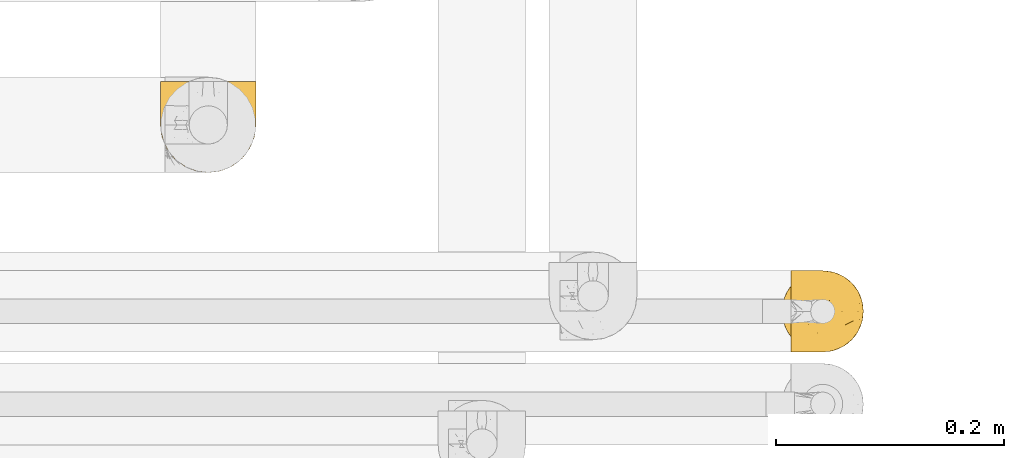
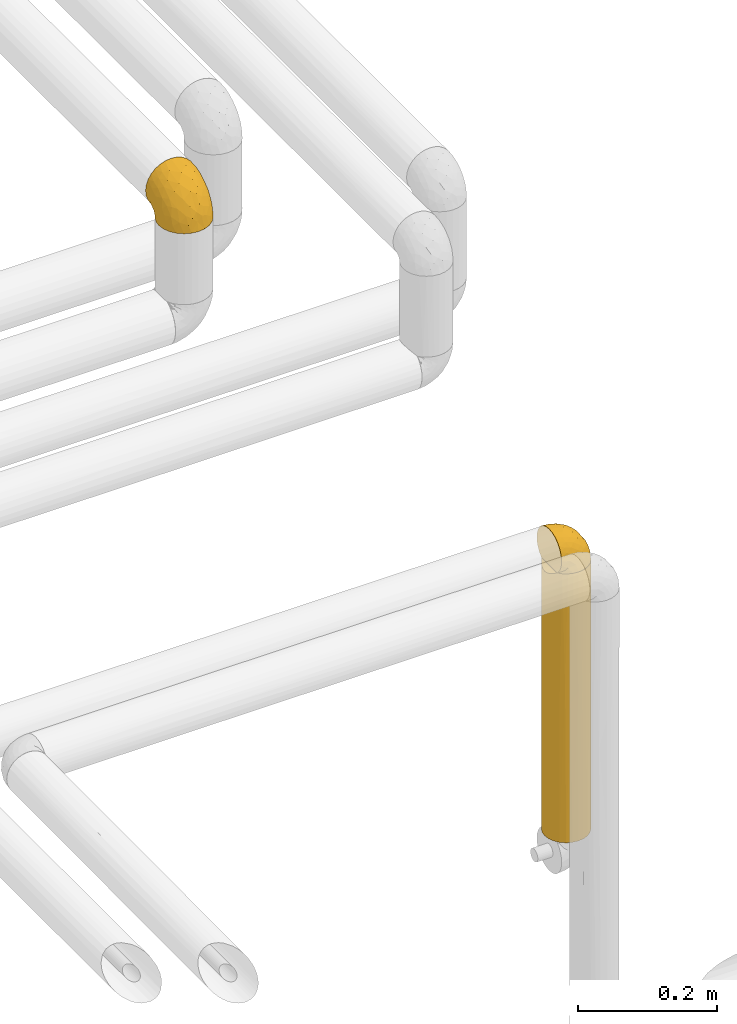
# One storey, part 93 of 827: 3 coverings.
"""IFC2X3 building model written with IfcOpenShell, lengths in millimetres."""

from ifc_helpers import new_model, entity, si_unit, converted_unit, derived_unit, direction, frame, origin, place, context, subcontext, project, spatial, faceted_brep, element, save


model = new_model("IFC2X3")

# Units and contexts
model_context = context("Model", 3, precision=0.01, world=origin(), true_north=direction((6.12303176911189e-17, 1.0)))
body_context = subcontext(model_context, "Body", "Model", "MODEL_VIEW")
ifc_project = project(units=[si_unit("LENGTHUNIT", "METRE", prefix="MILLI"), si_unit("AREAUNIT", "SQUARE_METRE"), si_unit("VOLUMEUNIT", "CUBIC_METRE"), converted_unit("PLANEANGLEUNIT", "DEGREE", entity("IfcRatioMeasure", 0.0174532925199433), si_unit("PLANEANGLEUNIT", "RADIAN"), dimensions=[0, 0, 0, 0, 0, 0, 0]), si_unit("MASSUNIT", "GRAM", prefix="KILO"), derived_unit("MASSDENSITYUNIT", [(si_unit("MASSUNIT", "GRAM", prefix="KILO"), 1), (si_unit("LENGTHUNIT", "METRE"), -3)]), derived_unit("MOMENTOFINERTIAUNIT", [(si_unit("LENGTHUNIT", "METRE"), 4)]), si_unit("TIMEUNIT", "SECOND"), si_unit("FREQUENCYUNIT", "HERTZ"), si_unit("THERMODYNAMICTEMPERATUREUNIT", "DEGREE_CELSIUS"), derived_unit("THERMALTRANSMITTANCEUNIT", [(si_unit("MASSUNIT", "GRAM", prefix="KILO"), 1), (si_unit("THERMODYNAMICTEMPERATUREUNIT", "KELVIN"), -1), (si_unit("TIMEUNIT", "SECOND"), -3)]), derived_unit("VOLUMETRICFLOWRATEUNIT", [(si_unit("LENGTHUNIT", "METRE"), 3), (si_unit("TIMEUNIT", "SECOND"), -1)]), derived_unit("MASSFLOWRATEUNIT", [(si_unit("MASSUNIT", "GRAM", prefix="KILO"), 1), (si_unit("TIMEUNIT", "SECOND"), -1)]), derived_unit("ROTATIONALFREQUENCYUNIT", [(si_unit("TIMEUNIT", "SECOND"), -1)]), si_unit("ELECTRICCURRENTUNIT", "AMPERE"), si_unit("ELECTRICVOLTAGEUNIT", "VOLT"), si_unit("POWERUNIT", "WATT"), si_unit("FORCEUNIT", "NEWTON", prefix="KILO"), si_unit("ILLUMINANCEUNIT", "LUX"), si_unit("LUMINOUSFLUXUNIT", "LUMEN"), si_unit("LUMINOUSINTENSITYUNIT", "CANDELA"), derived_unit("USERDEFINED", [(si_unit("MASSUNIT", "GRAM", prefix="KILO"), -1), (si_unit("LENGTHUNIT", "METRE"), -2), (si_unit("TIMEUNIT", "SECOND"), 3), (si_unit("LUMINOUSFLUXUNIT", "LUMEN"), 1)]), derived_unit("LINEARVELOCITYUNIT", [(si_unit("LENGTHUNIT", "METRE"), 1), (si_unit("TIMEUNIT", "SECOND"), -1)]), si_unit("PRESSUREUNIT", "PASCAL"), derived_unit("USERDEFINED", [(si_unit("LENGTHUNIT", "METRE"), -2), (si_unit("MASSUNIT", "GRAM", prefix="KILO"), 1), (si_unit("TIMEUNIT", "SECOND"), -2)]), derived_unit("LINEARFORCEUNIT", [(si_unit("MASSUNIT", "GRAM", prefix="KILO"), 1), (si_unit("LENGTHUNIT", "METRE"), 1), (si_unit("TIMEUNIT", "SECOND"), -2), (si_unit("LENGTHUNIT", "METRE"), -1)]), derived_unit("PLANARFORCEUNIT", [(si_unit("MASSUNIT", "GRAM", prefix="KILO"), 1), (si_unit("LENGTHUNIT", "METRE"), 1), (si_unit("TIMEUNIT", "SECOND"), -2), (si_unit("LENGTHUNIT", "METRE"), -2)])], contexts=[model_context])

# Site, building, storey
site_placement = place(None, origin())
site = spatial("IfcSite", under=ifc_project, at=site_placement, CompositionType="ELEMENT")
building_placement = place(site_placement, origin())
building = spatial("IfcBuilding", under=site, at=building_placement, CompositionType="ELEMENT")
storey_placement = place(building_placement, frame((0.0, 0.0, 28200.0)))
storey = spatial("IfcBuildingStorey", under=building, at=storey_placement, Name="08", CompositionType="ELEMENT", Elevation=28200.0)

# Coverings
covering_1_placement = place(storey_placement, frame((18847.33, 12899.2, 1400.7)))
element("IfcCovering", 1, at=covering_1_placement, inside=storey, Name=":ADSK_", ObjectType=":ADSK_", PredefinedType="INSULATION", context=body_context, shape_type="Brep", body=[
    faceted_brep([(62.45, 12.04, 471.3), (68.12, 19.42, 471.3), (71.68, 28.02, 471.3), (72.9, 37.25, 471.3), (71.68, 46.47, 471.3), (68.12, 55.07, 471.3), (62.45, 62.45, 471.3), (55.07, 68.12, 471.3), (46.47, 71.68, 471.3), (37.25, 72.9, 471.3), (29.26, 71.99, 471.3), (21.68, 69.32, 471.3), (14.89, 65.02, 471.3), (9.25, 59.31, 471.3), (9.25, 15.18, 471.3), (14.89, 9.47, 471.3), (21.68, 5.17, 471.3), (29.26, 2.5, 471.3), (37.25, 1.6, 471.3), (46.47, 2.81, 471.3), (55.07, 6.37, 471.3), (71.68, 28.02, 0.0), (68.12, 19.42, 0.0), (62.45, 12.04, 0.0), (55.07, 6.37, 0.0), (46.47, 2.81, 0.0), (37.25, 1.6, 0.0), (28.02, 2.81, 0.0), (19.42, 6.37, 0.0), (12.04, 12.04, 0.0), (6.37, 19.42, 0.0), (2.81, 28.02, 0.0), (1.6, 37.25, 0.0), (2.81, 46.47, 0.0), (6.37, 55.07, 0.0), (12.04, 62.45, 0.0), (19.42, 68.12, 0.0), (28.02, 71.68, 0.0), (37.25, 72.9, 0.0), (46.47, 71.68, 0.0), (55.07, 68.12, 0.0), (62.45, 62.45, 0.0), (68.12, 55.07, 0.0), (71.68, 46.47, 0.0), (72.9, 37.25, 0.0), (37.25, 72.9, 262.82), (37.25, 72.9, 235.65), (3.56, 48.92, 465.61), (4.7, 51.79, 229.25), (2.38, 44.7, 252.33), (18.18, 67.37, 268.97), (25.39, 70.87, 243.26), (11.91, 62.32, 249.89), (1.6, 37.25, 255.17), (7.9, 57.48, 177.22), (5.97, 54.35, 468.02), (1.6, 37.25, 463.65), (2.09, 43.17, 464.14), (4.7, 22.7, 229.25), (2.38, 29.79, 252.33), (7.77, 17.19, 292.58), (11.91, 12.17, 249.89), (25.39, 3.62, 243.26), (2.09, 31.32, 464.14), (5.97, 20.14, 468.02), (3.56, 25.57, 465.61), (18.18, 7.12, 268.97), (37.25, 1.6, 262.82), (44.26, 2.29, 278.16), (50.89, 4.31, 238.36), (72.21, 30.29, 276.73), (70.18, 23.6, 235.65), (58.95, 8.96, 235.65), (65.53, 15.54, 238.36), (72.9, 37.25, 235.65), (72.9, 37.25, 262.82), (72.2, 44.26, 278.16), (70.18, 50.89, 238.36), (44.2, 72.21, 276.73), (50.89, 70.18, 235.65), (65.53, 58.95, 235.65), (58.95, 65.53, 238.36)], [[[0, 1, 2, 3, 4, 5, 6, 7, 8, 9, 10, 11, 12, 13, 14, 15, 16, 17, 18, 19, 20]], [[21, 22, 23, 24, 25, 26, 27, 28, 29, 30, 31, 32, 33, 34, 35, 36, 37, 38, 39, 40, 41, 42, 43, 44]], [[37, 45, 46, 38]], [[47, 48, 49]], [[35, 50, 36]], [[36, 51, 37]], [[35, 52, 50]], [[53, 49, 32]], [[37, 51, 45]], [[36, 50, 51]], [[10, 51, 11]], [[51, 50, 11]], [[35, 34, 54]], [[52, 13, 12]], [[11, 50, 12]], [[55, 48, 47]], [[35, 54, 52]], [[33, 49, 48]], [[56, 57, 53]], [[54, 48, 55]], [[53, 57, 49]], [[10, 9, 45]], [[13, 52, 54]], [[34, 33, 48]], [[32, 49, 33]], [[55, 13, 54]], [[45, 51, 10]], [[47, 49, 57]], [[54, 34, 48]], [[12, 50, 52]], [[31, 58, 59]], [[59, 32, 31]], [[30, 60, 58]], [[60, 29, 61]], [[31, 30, 58]], [[62, 17, 16]], [[63, 53, 59]], [[58, 60, 64]], [[58, 64, 65]], [[65, 63, 59]], [[29, 60, 30]], [[63, 56, 53]], [[62, 66, 28]], [[65, 59, 58]], [[28, 27, 62]], [[66, 61, 29]], [[59, 53, 32]], [[67, 18, 17]], [[67, 62, 27]], [[16, 66, 62]], [[66, 29, 28]], [[15, 61, 66]], [[67, 17, 62]], [[60, 61, 14]], [[15, 66, 16]], [[61, 15, 14]], [[64, 60, 14]], [[26, 67, 27]], [[68, 25, 69]], [[21, 70, 71]], [[68, 18, 67, 26]], [[69, 72, 20]], [[72, 69, 24]], [[68, 26, 25]], [[23, 72, 24]], [[72, 0, 20]], [[20, 19, 69]], [[22, 71, 73]], [[70, 44, 74, 75, 3]], [[71, 22, 21]], [[71, 1, 73]], [[23, 73, 72]], [[0, 72, 73]], [[22, 73, 23]], [[68, 69, 19]], [[1, 0, 73]], [[71, 70, 2]], [[1, 71, 2]], [[24, 69, 25]], [[70, 21, 44]], [[18, 68, 19]], [[70, 3, 2]], [[76, 43, 77]], [[39, 78, 79]], [[76, 3, 75, 74, 44]], [[77, 80, 5]], [[80, 77, 42]], [[76, 44, 43]], [[41, 80, 42]], [[80, 6, 5]], [[5, 4, 77]], [[40, 79, 81]], [[78, 38, 46, 45, 9]], [[79, 40, 39]], [[79, 7, 81]], [[41, 81, 80]], [[6, 80, 81]], [[40, 81, 41]], [[76, 77, 4]], [[7, 6, 81]], [[79, 78, 8]], [[7, 79, 8]], [[42, 77, 43]], [[78, 39, 38]], [[3, 76, 4]], [[78, 9, 8]], [[57, 56, 63, 65, 64, 14, 13, 55, 47]]]),
])
covering_2_placement = place(storey_placement, frame((18854.98, 12899.2, 1870.4)))
element("IfcCovering", 2, at=covering_2_placement, inside=storey, Name=":ADSK_", ObjectType=":ADSK_", PredefinedType="INSULATION", context=body_context, shape_type="Brep", body=[
    faceted_brep([(1.6, 5.13, 45.07), (1.6, 9.38, 51.83), (1.6, 15.02, 57.47), (1.6, 21.78, 61.72), (1.6, 29.32, 64.35), (1.6, 37.25, 65.25), (1.6, 45.18, 64.35), (1.6, 52.72, 61.71), (1.6, 59.48, 57.46), (1.6, 65.12, 51.82), (1.6, 69.37, 45.06), (1.6, 72.0, 37.52), (1.6, 72.9, 29.6), (1.6, 72.01, 21.69), (1.6, 69.39, 14.19), (1.6, 65.18, 7.45), (1.6, 59.59, 1.82), (1.6, 57.53, 1.82), (1.6, 56.06, 1.82), (1.6, 54.3, 1.82), (1.6, 52.53, 1.82), (1.6, 50.77, 1.82), (1.6, 49.0, 1.82), (1.6, 47.24, 1.82), (1.6, 45.47, 1.82), (1.6, 43.71, 1.82), (1.6, 41.94, 1.82), (1.6, 40.18, 1.82), (1.6, 38.41, 1.82), (1.6, 36.65, 1.82), (1.6, 34.88, 1.82), (1.6, 33.12, 1.82), (1.6, 31.35, 1.82), (1.6, 29.3, 1.82), (1.6, 27.24, 1.82), (1.6, 25.18, 1.82), (1.6, 23.13, 1.82), (1.6, 21.07, 1.82), (1.6, 19.01, 1.82), (1.6, 16.96, 1.82), (1.6, 14.9, 1.82), (1.6, 9.3, 7.46), (1.6, 5.09, 14.2), (1.6, 2.48, 21.71), (1.6, 1.6, 29.6), (1.6, 2.49, 37.53), (1.82, 59.59, 1.6), (7.46, 65.19, 1.6), (14.2, 69.4, 1.6), (21.7, 72.01, 1.6), (29.6, 72.9, 1.6), (38.82, 71.68, 1.6), (47.42, 68.12, 1.6), (54.8, 62.45, 1.6), (60.47, 55.07, 1.6), (64.03, 46.47, 1.6), (65.25, 37.25, 1.6), (64.03, 28.02, 1.6), (60.47, 19.42, 1.6), (54.8, 12.04, 1.6), (47.42, 6.37, 1.6), (38.82, 2.81, 1.6), (29.6, 1.6, 1.6), (21.7, 2.48, 1.6), (14.2, 5.09, 1.6), (7.46, 9.3, 1.6), (1.82, 14.9, 1.6), (1.82, 15.93, 1.6), (1.82, 17.69, 1.6), (1.82, 19.09, 1.6), (1.82, 20.49, 1.6), (1.82, 21.88, 1.6), (1.82, 23.28, 1.6), (1.82, 24.68, 1.6), (1.82, 26.07, 1.6), (1.82, 27.47, 1.6), (1.82, 28.87, 1.6), (1.82, 30.26, 1.6), (1.82, 31.66, 1.6), (1.82, 33.06, 1.6), (1.82, 34.45, 1.6), (1.82, 35.85, 1.6), (1.82, 37.25, 1.6), (1.82, 39.01, 1.6), (1.82, 40.77, 1.6), (1.82, 42.54, 1.6), (1.82, 44.3, 1.6), (1.82, 46.07, 1.6), (1.82, 47.83, 1.6), (1.82, 49.6, 1.6), (1.82, 51.36, 1.6), (1.82, 53.42, 1.6), (1.82, 55.48, 1.6), (1.82, 57.53, 1.6), (1.75, 24.13, 1.76), (1.76, 22.58, 1.75), (1.76, 46.76, 1.75), (1.76, 45.43, 1.74), (1.74, 51.49, 1.76), (1.76, 35.2, 1.75), (1.75, 58.19, 1.75), (1.75, 56.8, 1.75), (1.75, 32.4, 1.75), (1.76, 30.96, 1.75), (1.74, 16.26, 1.76), (1.75, 14.9, 1.75), (1.74, 28.17, 1.76), (1.76, 26.81, 1.75), (1.75, 55.49, 1.76), (1.75, 44.1, 1.75), (1.74, 42.83, 1.77), (1.76, 36.55, 1.74), (1.76, 37.92, 1.75), (1.76, 29.48, 1.75), (1.73, 39.3, 1.77), (1.74, 48.12, 1.77), (1.75, 49.39, 1.75), (1.74, 17.58, 1.76), (1.75, 33.81, 1.75), (1.78, 41.72, 1.71), (1.76, 54.15, 1.74), (1.76, 52.82, 1.75), (1.75, 40.57, 1.75), (1.76, 21.1, 1.74), (1.75, 19.79, 1.75), (1.75, 59.59, 1.75), (1.76, 25.46, 1.75), (13.11, 70.91, 13.1), (8.18, 68.25, 9.65), (25.84, 72.9, 15.6), (28.13, 72.9, 7.07), (15.6, 72.9, 25.84), (5.2, 64.57, 5.2), (20.72, 72.9, 20.72), (7.07, 72.9, 28.13), (35.56, 46.9, 53.84), (16.98, 49.02, 61.29), (25.95, 37.25, 60.4), (35.4, 72.16, 11.45), (32.74, 72.12, 18.37), (43.51, 65.96, 27.21), (53.51, 58.95, 23.34), (49.6, 65.53, 14.46), (40.07, 70.18, 17.53), (42.61, 70.18, 8.83), (20.45, 67.43, 44.61), (10.52, 67.43, 47.7), (14.87, 62.46, 53.12), (24.92, 72.19, 27.74), (34.61, 53.36, 51.46), (61.84, 43.86, 20.14), (60.43, 50.89, 17.44), (14.29, 37.25, 62.72), (57.0, 58.95, 11.49), (42.79, 55.84, 43.01), (33.34, 59.19, 47.84), (21.53, 71.35, 34.4), (11.52, 70.9, 40.11), (12.66, 56.22, 58.72), (34.11, 67.42, 35.5), (32.29, 70.63, 28.03), (24.41, 61.45, 50.73), (24.95, 56.22, 54.88), (44.19, 48.22, 46.53), (56.24, 51.43, 28.03), (56.83, 45.24, 31.36), (50.94, 50.08, 37.9), (50.38, 43.45, 41.63), (46.6, 37.25, 46.6), (36.28, 37.25, 53.5), (62.72, 37.25, 14.29), (47.39, 59.41, 33.68), (38.92, 62.46, 39.51), (29.55, 64.67, 43.98), (26.82, 68.35, 39.36), (60.4, 37.25, 25.95), (53.5, 37.25, 36.28), (41.8, 4.31, 12.43), (61.8, 30.45, 20.13), (49.33, 25.32, 40.53), (35.54, 27.59, 53.86), (14.87, 12.04, 53.13), (12.65, 18.28, 58.72), (47.44, 8.96, 20.81), (56.06, 15.54, 15.78), (50.17, 16.32, 31.15), (20.44, 7.06, 44.62), (10.52, 7.06, 47.71), (11.52, 3.6, 40.12), (38.79, 19.36, 47.19), (33.87, 2.28, 14.97), (25.84, 1.6, 15.6), (27.72, 1.6, 8.6), (7.07, 1.6, 28.13), (62.13, 25.07, 12.48), (50.52, 8.96, 10.34), (56.47, 29.08, 31.94), (58.39, 23.6, 23.68), (16.98, 25.48, 61.3), (39.3, 7.69, 31.18), (38.56, 4.1, 19.63), (24.94, 18.28, 54.89), (30.34, 2.18, 20.57), (26.49, 2.39, 26.89), (15.6, 1.6, 25.84), (20.72, 1.6, 20.72), (26.6, 12.04, 48.57), (21.54, 3.15, 34.41), (35.7, 2.24, 8.15), (38.91, 12.04, 39.53), (30.65, 6.5, 37.32), (44.9, 11.64, 31.82), (34.09, 3.92, 26.03), (13.11, 3.58, 13.1), (9.65, 6.24, 8.18), (5.2, 9.92, 5.2)], [[[0, 1, 2, 3, 4, 5, 6, 7, 8, 9, 10, 11, 12, 13, 14, 15, 16, 17, 18, 19, 20, 21, 22, 23, 24, 25, 26, 27, 28, 29, 30, 31, 32, 33, 34, 35, 36, 37, 38, 39, 40, 41, 42, 43, 44, 45]], [[46, 47, 48, 49, 50, 51, 52, 53, 54, 55, 56, 57, 58, 59, 60, 61, 62, 63, 64, 65, 66, 67, 68, 69, 70, 71, 72, 73, 74, 75, 76, 77, 78, 79, 80, 81, 82, 83, 84, 85, 86, 87, 88, 89, 90, 91, 92, 93]], [[94, 72, 95]], [[96, 87, 97]], [[20, 98, 21]], [[99, 81, 80]], [[100, 93, 101]], [[102, 103, 32]], [[104, 105, 40]], [[67, 105, 104]], [[106, 107, 34]], [[18, 101, 108]], [[109, 85, 110]], [[36, 94, 95]], [[81, 111, 82]], [[29, 28, 112]], [[17, 101, 18]], [[103, 113, 33]], [[24, 96, 97]], [[28, 114, 112]], [[115, 22, 116]], [[31, 102, 32]], [[68, 104, 117]], [[31, 118, 102]], [[84, 119, 85]], [[120, 91, 121]], [[23, 22, 115]], [[114, 27, 122]], [[123, 37, 95]], [[117, 124, 69]], [[67, 66, 105]], [[104, 39, 117]], [[123, 124, 37]], [[100, 17, 16]], [[100, 125, 46]], [[17, 100, 101]], [[107, 126, 35]], [[92, 108, 101]], [[115, 88, 96]], [[114, 122, 83]], [[101, 93, 92]], [[93, 100, 46]], [[16, 125, 100]], [[108, 19, 18]], [[120, 121, 19]], [[108, 92, 120]], [[19, 108, 120]], [[67, 104, 68]], [[39, 104, 40]], [[69, 68, 117]], [[117, 39, 38]], [[70, 124, 123]], [[124, 70, 69]], [[38, 124, 117]], [[124, 38, 37]], [[72, 71, 95]], [[71, 123, 95]], [[71, 70, 123]], [[126, 94, 35]], [[37, 36, 95]], [[75, 74, 107]], [[73, 72, 94]], [[94, 36, 35]], [[94, 126, 73]], [[74, 73, 126]], [[106, 76, 75]], [[76, 106, 113]], [[113, 106, 33]], [[107, 35, 34]], [[106, 34, 33]], [[126, 107, 74]], [[107, 106, 75]], [[78, 77, 103]], [[77, 113, 103]], [[77, 76, 113]], [[102, 78, 103]], [[33, 32, 103]], [[80, 79, 118]], [[102, 118, 79]], [[112, 111, 29]], [[118, 31, 30]], [[79, 78, 102]], [[99, 111, 81]], [[112, 82, 111]], [[111, 99, 29]], [[30, 29, 99]], [[112, 83, 82]], [[27, 114, 28]], [[99, 118, 30]], [[118, 99, 80]], [[114, 83, 112]], [[84, 83, 122]], [[109, 110, 25]], [[122, 27, 26]], [[119, 110, 85]], [[20, 19, 121]], [[25, 110, 26]], [[91, 120, 92]], [[90, 98, 121]], [[121, 91, 90]], [[23, 115, 96]], [[88, 115, 116]], [[116, 98, 89]], [[89, 88, 116]], [[23, 96, 24]], [[87, 96, 88]], [[25, 24, 109]], [[97, 87, 86]], [[90, 89, 98]], [[116, 22, 21]], [[122, 26, 119]], [[86, 85, 109]], [[109, 97, 86]], [[97, 109, 24]], [[110, 119, 26]], [[122, 119, 84]], [[121, 98, 20]], [[21, 98, 116]], [[48, 127, 49]], [[48, 47, 128]], [[49, 129, 130, 50]], [[129, 49, 127]], [[131, 127, 13]], [[46, 125, 132]], [[16, 15, 132]], [[127, 128, 14]], [[127, 131, 133, 129]], [[14, 13, 127]], [[13, 12, 134, 131]], [[46, 132, 47]], [[48, 128, 127]], [[47, 132, 128]], [[15, 128, 132]], [[125, 16, 132]], [[15, 14, 128]], [[135, 136, 137]], [[138, 129, 139]], [[140, 141, 142]], [[143, 144, 138]], [[145, 146, 147]], [[133, 148, 139]], [[134, 12, 11]], [[136, 135, 149]], [[150, 55, 151]], [[136, 6, 152]], [[153, 54, 53]], [[52, 144, 142]], [[52, 142, 53]], [[54, 153, 151]], [[144, 52, 51]], [[154, 155, 149]], [[156, 131, 157]], [[134, 11, 157]], [[8, 7, 158]], [[147, 9, 8]], [[157, 131, 134]], [[157, 11, 10]], [[146, 157, 10]], [[159, 140, 160]], [[157, 145, 156]], [[161, 162, 155]], [[161, 147, 162]], [[154, 149, 163]], [[150, 164, 165]], [[136, 7, 6]], [[137, 136, 152]], [[162, 158, 136]], [[54, 151, 55]], [[158, 147, 8]], [[166, 167, 165]], [[9, 146, 10]], [[164, 166, 165]], [[168, 135, 137, 169]], [[55, 150, 170]], [[154, 171, 172]], [[139, 148, 160]], [[140, 142, 143]], [[153, 142, 141]], [[51, 50, 130]], [[145, 173, 174]], [[156, 160, 148]], [[6, 5, 152]], [[136, 158, 7]], [[147, 158, 162]], [[147, 146, 9]], [[157, 146, 145]], [[160, 140, 143]], [[140, 172, 171]], [[139, 143, 138]], [[173, 159, 174]], [[170, 150, 175]], [[170, 56, 55]], [[167, 168, 176]], [[176, 175, 165]], [[150, 165, 175]], [[163, 167, 166]], [[176, 165, 167]], [[164, 150, 151]], [[151, 141, 164]], [[171, 164, 141]], [[154, 163, 166]], [[163, 135, 168]], [[166, 164, 171]], [[155, 154, 172]], [[166, 171, 154]], [[140, 171, 141]], [[173, 155, 172]], [[149, 155, 162]], [[159, 173, 172]], [[161, 145, 147]], [[140, 159, 172]], [[174, 160, 156]], [[136, 149, 162]], [[149, 135, 163]], [[155, 173, 161]], [[145, 161, 173]], [[160, 174, 159]], [[156, 148, 131]], [[156, 145, 174]], [[142, 153, 53]], [[151, 153, 141]], [[138, 51, 130]], [[142, 144, 143]], [[51, 138, 144]], [[129, 138, 130]], [[133, 139, 129]], [[160, 143, 139]], [[168, 167, 163]], [[131, 148, 133]], [[60, 177, 61]], [[175, 178, 170]], [[179, 168, 180]], [[178, 57, 170]], [[181, 182, 2]], [[183, 184, 185]], [[186, 187, 188]], [[189, 185, 179]], [[190, 191, 192]], [[45, 193, 188]], [[194, 184, 58]], [[45, 44, 193]], [[59, 195, 60]], [[60, 195, 177]], [[0, 45, 188]], [[196, 179, 197]], [[180, 137, 198]], [[183, 199, 200]], [[201, 182, 181]], [[1, 181, 2]], [[57, 178, 194]], [[198, 3, 182]], [[198, 152, 4]], [[1, 0, 187]], [[190, 202, 191]], [[203, 204, 205]], [[206, 201, 181]], [[186, 188, 207]], [[188, 204, 207]], [[3, 198, 4]], [[58, 184, 59]], [[187, 181, 1]], [[180, 198, 201]], [[206, 181, 186]], [[180, 189, 179]], [[3, 2, 182]], [[180, 168, 169, 137]], [[204, 188, 193]], [[177, 190, 208]], [[209, 210, 199]], [[210, 186, 207]], [[185, 184, 197]], [[195, 184, 183]], [[205, 202, 203]], [[210, 209, 206]], [[179, 185, 197]], [[211, 209, 199]], [[196, 197, 178]], [[180, 201, 189]], [[152, 198, 137]], [[152, 5, 4]], [[61, 208, 62]], [[198, 182, 201]], [[188, 187, 0]], [[181, 187, 186]], [[203, 210, 207]], [[202, 205, 191]], [[199, 210, 212]], [[57, 56, 170]], [[176, 196, 175]], [[178, 197, 194]], [[179, 176, 168]], [[175, 196, 178]], [[176, 179, 196]], [[184, 194, 197]], [[58, 57, 194]], [[208, 190, 192]], [[200, 190, 177]], [[206, 189, 201]], [[185, 189, 209]], [[62, 208, 192]], [[177, 208, 61]], [[210, 206, 186]], [[189, 206, 209]], [[200, 199, 212]], [[211, 183, 185]], [[184, 195, 59]], [[177, 195, 183]], [[183, 200, 177]], [[202, 200, 212]], [[200, 202, 190]], [[202, 212, 203]], [[210, 203, 212]], [[204, 203, 207]], [[183, 211, 199]], [[185, 209, 211]], [[63, 62, 192, 191]], [[64, 63, 213]], [[64, 213, 214]], [[65, 215, 66]], [[213, 191, 205, 204]], [[43, 204, 193, 44]], [[65, 214, 215]], [[42, 213, 43]], [[215, 105, 66]], [[41, 214, 42]], [[40, 105, 215]], [[65, 64, 214]], [[40, 215, 41]], [[213, 63, 191]], [[42, 214, 213]], [[204, 43, 213]], [[214, 41, 215]]]),
])
covering_3_placement = place(storey_placement, frame((18302.11, 13056.55, 2560.4)))
element("IfcCovering", 3, at=covering_3_placement, inside=storey, Name=":ADSK_", ObjectType=":ADSK_", PredefinedType="INSULATION", context=body_context, shape_type="Brep", body=[
    faceted_brep([(5.74, 81.45, 57.76), (10.73, 81.45, 65.69), (17.36, 81.45, 72.32), (25.29, 81.45, 77.3), (34.14, 81.45, 80.4), (43.45, 81.45, 81.45), (52.76, 81.45, 80.39), (61.61, 81.45, 77.3), (69.54, 81.45, 72.31), (76.17, 81.45, 65.68), (81.15, 81.45, 57.75), (84.25, 81.45, 48.9), (85.3, 81.45, 39.6), (84.23, 81.45, 30.22), (81.1, 81.45, 21.33), (76.06, 81.45, 13.37), (69.36, 81.45, 6.73), (61.36, 81.45, 1.77), (60.44, 81.45, 1.77), (59.52, 81.45, 1.77), (58.72, 81.45, 1.77), (57.4, 81.45, 1.77), (56.08, 81.45, 1.77), (54.76, 81.45, 1.77), (53.44, 81.45, 1.77), (52.12, 81.45, 1.77), (50.8, 81.45, 1.77), (49.47, 81.45, 1.77), (48.15, 81.45, 1.77), (46.83, 81.45, 1.77), (45.51, 81.45, 1.77), (44.19, 81.45, 1.77), (42.87, 81.45, 1.77), (41.55, 81.45, 1.77), (40.23, 81.45, 1.77), (39.31, 81.45, 1.77), (38.39, 81.45, 1.77), (37.48, 81.45, 1.77), (36.56, 81.45, 1.77), (35.64, 81.45, 1.77), (34.72, 81.45, 1.77), (33.8, 81.45, 1.77), (32.88, 81.45, 1.77), (31.96, 81.45, 1.77), (31.05, 81.45, 1.77), (30.13, 81.45, 1.77), (29.21, 81.45, 1.77), (28.29, 81.45, 1.77), (27.37, 81.45, 1.77), (26.45, 81.45, 1.77), (25.53, 81.45, 1.77), (17.52, 81.45, 6.74), (10.82, 81.45, 13.38), (5.78, 81.45, 21.35), (2.65, 81.45, 30.24), (1.6, 81.45, 39.6), (2.65, 81.45, 48.91), (69.37, 76.3, 1.6), (76.06, 69.67, 1.6), (81.1, 61.7, 1.6), (84.23, 52.81, 1.6), (85.3, 43.45, 1.6), (83.87, 32.61, 1.6), (79.69, 22.52, 1.6), (73.04, 13.85, 1.6), (64.37, 7.2, 1.6), (54.28, 3.02, 1.6), (43.45, 1.6, 1.6), (32.61, 3.02, 1.6), (22.52, 7.2, 1.6), (13.85, 13.85, 1.6), (7.2, 22.52, 1.6), (3.02, 32.61, 1.6), (1.6, 43.45, 1.6), (2.66, 52.81, 1.6), (5.79, 61.7, 1.6), (10.83, 69.67, 1.6), (17.52, 76.3, 1.6), (25.53, 81.27, 1.6), (26.45, 81.27, 1.6), (27.77, 81.27, 1.6), (28.89, 81.27, 1.6), (30.01, 81.27, 1.6), (31.13, 81.27, 1.6), (32.25, 81.27, 1.6), (33.37, 81.27, 1.6), (34.49, 81.27, 1.6), (35.61, 81.27, 1.6), (36.73, 81.27, 1.6), (37.85, 81.27, 1.6), (38.97, 81.27, 1.6), (40.09, 81.27, 1.6), (41.21, 81.27, 1.6), (42.33, 81.27, 1.6), (43.45, 81.27, 1.6), (44.77, 81.27, 1.6), (46.09, 81.27, 1.6), (47.41, 81.27, 1.6), (48.73, 81.27, 1.6), (50.05, 81.27, 1.6), (51.37, 81.27, 1.6), (52.69, 81.27, 1.6), (54.01, 81.27, 1.6), (54.93, 81.27, 1.6), (55.85, 81.27, 1.6), (56.76, 81.27, 1.6), (57.68, 81.27, 1.6), (58.6, 81.27, 1.6), (59.52, 81.27, 1.6), (60.44, 81.27, 1.6), (61.36, 81.27, 1.6), (32.81, 81.31, 1.71), (31.73, 81.33, 1.73), (50.71, 81.31, 1.71), (51.76, 81.32, 1.72), (42.89, 81.31, 1.71), (41.81, 81.32, 1.72), (25.53, 81.32, 1.72), (26.91, 81.32, 1.72), (40.71, 81.32, 1.72), (60.15, 81.32, 1.72), (39.53, 81.32, 1.72), (57.22, 81.32, 1.72), (58.17, 81.3, 1.7), (47.12, 81.32, 1.72), (33.93, 81.33, 1.73), (35.05, 81.31, 1.72), (46.09, 81.33, 1.73), (45.02, 81.32, 1.73), (43.95, 81.32, 1.72), (59.12, 81.32, 1.72), (38.49, 81.31, 1.71), (49.68, 81.32, 1.72), (53.35, 81.31, 1.71), (54.4, 81.32, 1.72), (56.2, 81.32, 1.72), (36.2, 81.32, 1.72), (37.29, 81.33, 1.73), (30.57, 81.32, 1.72), (29.45, 81.31, 1.71), (28.01, 81.33, 1.73), (61.36, 81.32, 1.72), (25.53, 81.36, 1.74), (25.53, 81.4, 1.75), (61.36, 81.4, 1.75), (61.36, 81.36, 1.74), (25.53, 81.29, 1.64), (61.36, 81.3, 1.68), (61.36, 81.29, 1.64), (55.3, 81.35, 1.74), (48.18, 81.31, 1.71), (82.92, 58.5, 8.98), (85.3, 71.95, 37.05), (82.92, 74.57, 24.69), (78.8, 73.93, 15.28), (78.8, 78.18, 16.86), (70.46, 78.04, 6.58), (71.16, 76.23, 5.71), (85.3, 45.99, 11.1), (76.1, 74.01, 10.79), (72.9, 73.57, 4.13), (78.81, 66.66, 6.62), (72.89, 79.09, 9.52), (74.06, 73.14, 6.14), (83.71, 60.34, 17.79), (85.3, 48.54, 20.6), (85.3, 45.36, 8.73), (83.61, 67.22, 23.66), (85.3, 62.45, 34.5), (80.61, 68.67, 15.32), (85.3, 55.49, 27.55), (67.83, 77.84, 3.31), (78.81, 68.16, 9.81), (85.3, 74.31, 37.68), (54.78, 38.78, 67.23), (57.27, 62.1, 76.64), (43.45, 50.89, 75.37), (84.45, 36.91, 14.58), (84.39, 40.37, 23.71), (77.16, 27.86, 34.34), (68.92, 15.77, 29.1), (76.65, 20.13, 18.02), (82.11, 31.54, 22.27), (82.11, 28.25, 10.97), (78.88, 57.26, 56.79), (78.88, 69.99, 60.76), (73.04, 64.58, 67.04), (84.47, 50.64, 36.11), (65.72, 51.97, 68.85), (51.16, 5.72, 24.58), (59.46, 7.42, 21.54), (43.45, 66.14, 78.4), (68.92, 11.35, 14.11), (51.18, 21.64, 53.42), (57.42, 28.57, 58.19), (83.48, 55.38, 44.49), (82.95, 68.51, 51.77), (65.72, 67.48, 73.69), (78.97, 40.78, 45.89), (82.64, 41.53, 35.97), (75.14, 46.11, 56.55), (68.58, 40.32, 60.03), (61.95, 38.36, 63.64), (58.11, 11.84, 34.98), (51.07, 12.56, 40.58), (43.45, 7.67, 32.15), (58.51, 19.39, 47.26), (43.45, 24.98, 58.06), (43.45, 37.94, 66.71), (43.45, 4.64, 16.9), (65.68, 28.09, 52.08), (70.41, 23.73, 41.21), (73.04, 34.03, 49.76), (43.45, 16.33, 45.11), (4.78, 29.29, 15.65), (35.48, 5.77, 24.57), (29.45, 21.44, 50.54), (32.11, 38.8, 67.25), (13.86, 64.58, 67.06), (21.19, 67.49, 73.7), (10.24, 22.9, 26.13), (17.97, 12.54, 19.54), (18.88, 20.04, 38.96), (8.01, 57.26, 56.8), (8.01, 69.99, 60.77), (3.95, 68.51, 51.78), (22.45, 34.54, 59.09), (2.4, 38.81, 19.25), (1.6, 48.54, 20.6), (1.6, 45.99, 11.1), (1.6, 74.31, 37.68), (29.05, 5.36, 15.21), (10.24, 18.96, 12.76), (35.7, 12.79, 40.93), (29.63, 62.11, 76.65), (8.75, 33.14, 39.5), (4.54, 33.44, 25.01), (21.19, 51.98, 68.86), (2.28, 43.42, 26.7), (2.53, 48.62, 34.95), (1.6, 62.45, 34.5), (1.6, 55.49, 27.55), (13.86, 49.68, 61.27), (3.41, 55.37, 44.5), (1.6, 71.95, 37.05), (2.35, 36.37, 10.25), (13.86, 34.04, 49.78), (7.35, 44.1, 47.51), (27.43, 9.99, 29.38), (13.39, 26.41, 40.01), (4.32, 39.19, 33.36), (3.97, 58.5, 8.98), (3.27, 67.22, 23.67), (3.97, 74.57, 24.71), (8.08, 73.92, 15.29), (13.99, 73.57, 4.13), (12.83, 73.14, 6.14), (8.08, 66.19, 4.96), (8.08, 68.16, 9.81), (19.06, 77.84, 3.31), (15.74, 76.23, 5.7), (25.53, 81.3, 1.68), (13.98, 79.08, 9.53), (16.42, 78.04, 6.59), (8.08, 77.18, 16.63), (6.27, 68.66, 15.34), (10.78, 74.0, 10.8), (3.18, 60.34, 17.79)], [[[0, 1, 2, 3, 4, 5, 6, 7, 8, 9, 10, 11, 12, 13, 14, 15, 16, 17, 18, 19, 20, 21, 22, 23, 24, 25, 26, 27, 28, 29, 30, 31, 32, 33, 34, 35, 36, 37, 38, 39, 40, 41, 42, 43, 44, 45, 46, 47, 48, 49, 50, 51, 52, 53, 54, 55, 56]], [[57, 58, 59, 60, 61, 62, 63, 64, 65, 66, 67, 68, 69, 70, 71, 72, 73, 74, 75, 76, 77, 78, 79, 80, 81, 82, 83, 84, 85, 86, 87, 88, 89, 90, 91, 92, 93, 94, 95, 96, 97, 98, 99, 100, 101, 102, 103, 104, 105, 106, 107, 108, 109, 110]], [[111, 84, 112]], [[113, 26, 114]], [[114, 101, 100]], [[115, 93, 116]], [[79, 117, 118]], [[33, 116, 119]], [[117, 49, 118]], [[19, 18, 120]], [[119, 121, 34]], [[122, 21, 123]], [[97, 96, 124]], [[86, 125, 126]], [[116, 92, 119]], [[127, 96, 128]], [[32, 129, 115]], [[19, 120, 130]], [[121, 90, 131]], [[94, 115, 129]], [[115, 116, 32]], [[118, 49, 48]], [[113, 99, 132]], [[133, 114, 25]], [[24, 134, 133]], [[135, 22, 122]], [[136, 137, 88]], [[84, 83, 112]], [[138, 82, 139]], [[130, 20, 19]], [[118, 48, 140]], [[81, 140, 139]], [[123, 21, 20]], [[141, 120, 18]], [[139, 82, 81]], [[130, 107, 123]], [[49, 117, 142, 143, 50]], [[18, 17, 144, 145, 141]], [[79, 78, 146]], [[109, 141, 147, 148]], [[102, 133, 134]], [[105, 135, 122]], [[118, 80, 79]], [[80, 118, 140]], [[120, 109, 108]], [[47, 46, 140, 48]], [[81, 80, 140]], [[44, 112, 138]], [[93, 115, 94]], [[46, 139, 140]], [[46, 45, 139]], [[139, 45, 138]], [[138, 112, 83]], [[85, 84, 111]], [[112, 43, 111]], [[83, 82, 138]], [[106, 122, 123]], [[105, 122, 106]], [[21, 122, 22]], [[124, 29, 28]], [[33, 32, 116]], [[128, 129, 31]], [[32, 31, 129]], [[34, 33, 119]], [[116, 93, 92]], [[129, 95, 94]], [[95, 129, 128]], [[41, 40, 125, 42]], [[119, 91, 121]], [[36, 35, 131, 37]], [[137, 131, 89]], [[121, 131, 35]], [[90, 121, 91]], [[119, 92, 91]], [[136, 126, 39]], [[125, 86, 85]], [[42, 125, 111]], [[85, 111, 125]], [[149, 23, 22]], [[130, 108, 107]], [[130, 123, 20]], [[107, 106, 123]], [[137, 37, 131]], [[136, 38, 137]], [[89, 88, 137]], [[131, 90, 89]], [[124, 150, 97]], [[40, 39, 126]], [[87, 126, 136]], [[86, 126, 87]], [[136, 88, 87]], [[40, 126, 125]], [[39, 38, 136]], [[95, 128, 96]], [[30, 128, 31]], [[29, 124, 127]], [[127, 128, 30]], [[150, 124, 28]], [[127, 30, 29]], [[127, 124, 96]], [[150, 98, 97]], [[45, 44, 138]], [[26, 113, 132]], [[113, 100, 99]], [[132, 150, 27]], [[27, 26, 132]], [[26, 25, 114]], [[100, 113, 114]], [[101, 133, 102]], [[133, 101, 114]], [[28, 27, 150]], [[132, 99, 98]], [[23, 134, 24]], [[25, 24, 133]], [[134, 23, 149]], [[135, 104, 149]], [[149, 104, 103]], [[103, 102, 134]], [[130, 120, 108]], [[109, 120, 141]], [[42, 111, 43]], [[112, 44, 43]], [[104, 135, 105]], [[134, 149, 103]], [[135, 149, 22]], [[35, 34, 121]], [[137, 38, 37]], [[98, 150, 132]], [[59, 151, 60]], [[13, 152, 153]], [[154, 155, 153]], [[156, 157, 141]], [[158, 60, 151]], [[159, 156, 154]], [[160, 161, 58]], [[58, 161, 59]], [[144, 16, 162]], [[58, 57, 160]], [[161, 160, 163]], [[156, 162, 154]], [[162, 16, 15]], [[57, 148, 160]], [[151, 164, 165]], [[156, 144, 162]], [[60, 158, 166, 61]], [[155, 14, 153]], [[162, 155, 154]], [[154, 153, 167]], [[167, 153, 168]], [[154, 169, 159]], [[57, 110, 148]], [[144, 17, 16]], [[155, 15, 14]], [[170, 164, 167]], [[157, 163, 171]], [[14, 13, 153]], [[156, 141, 145, 144]], [[172, 163, 157]], [[172, 159, 169]], [[170, 165, 164]], [[167, 164, 169]], [[167, 168, 170]], [[151, 172, 164]], [[169, 154, 167]], [[164, 172, 169]], [[159, 172, 157]], [[171, 148, 147]], [[147, 141, 157]], [[157, 156, 159]], [[151, 165, 158]], [[172, 151, 161]], [[59, 161, 151]], [[13, 12, 173, 152]], [[152, 168, 153]], [[15, 155, 162]], [[161, 163, 172]], [[171, 163, 160]], [[148, 171, 160]], [[157, 171, 147]], [[174, 175, 176]], [[177, 165, 178]], [[179, 180, 181]], [[182, 183, 177]], [[184, 185, 186]], [[170, 187, 178]], [[173, 12, 11]], [[188, 175, 174]], [[189, 66, 190]], [[175, 6, 191]], [[192, 65, 64]], [[63, 183, 181]], [[63, 181, 64]], [[65, 192, 190]], [[183, 63, 62]], [[174, 193, 194]], [[195, 168, 196]], [[173, 11, 196]], [[8, 7, 197]], [[186, 9, 8]], [[196, 168, 152, 173]], [[196, 11, 10]], [[185, 196, 10]], [[198, 179, 199]], [[196, 184, 195]], [[200, 188, 201]], [[200, 186, 188]], [[194, 202, 174]], [[190, 203, 189]], [[175, 7, 6]], [[176, 175, 191]], [[188, 197, 175]], [[65, 190, 66]], [[197, 186, 8]], [[204, 205, 189]], [[9, 185, 10]], [[180, 206, 203]], [[207, 174, 176, 208]], [[66, 189, 209]], [[210, 211, 212]], [[189, 203, 204]], [[179, 181, 182]], [[192, 181, 180]], [[62, 61, 166]], [[195, 184, 198]], [[195, 199, 187]], [[6, 5, 191]], [[175, 197, 7]], [[186, 197, 188]], [[186, 185, 9]], [[196, 185, 184]], [[199, 179, 182]], [[179, 212, 211]], [[178, 182, 177]], [[184, 200, 198]], [[209, 189, 205]], [[209, 67, 66]], [[204, 203, 206]], [[193, 204, 206]], [[193, 213, 204]], [[194, 193, 206]], [[207, 193, 174]], [[206, 210, 194]], [[201, 202, 210]], [[211, 206, 180]], [[201, 210, 212]], [[200, 201, 212]], [[188, 174, 202]], [[198, 200, 212]], [[186, 200, 184]], [[179, 198, 212]], [[195, 198, 199]], [[210, 202, 194]], [[188, 202, 201]], [[206, 211, 210]], [[179, 211, 180]], [[213, 193, 207]], [[213, 205, 204]], [[195, 187, 168]], [[180, 203, 190]], [[181, 192, 64]], [[190, 192, 180]], [[177, 62, 166]], [[181, 183, 182]], [[62, 177, 183]], [[177, 166, 158, 165]], [[170, 178, 165]], [[199, 182, 178]], [[178, 187, 199]], [[168, 187, 170]], [[71, 214, 72]], [[205, 215, 209]], [[216, 207, 217]], [[215, 68, 209]], [[218, 219, 2]], [[220, 221, 222]], [[223, 224, 225]], [[226, 222, 216]], [[227, 228, 229]], [[56, 230, 225]], [[231, 221, 69]], [[56, 55, 230]], [[70, 232, 71]], [[71, 232, 214]], [[0, 56, 225]], [[207, 216, 233]], [[217, 176, 234]], [[220, 235, 236]], [[237, 219, 218]], [[1, 218, 2]], [[68, 215, 231]], [[234, 3, 219]], [[234, 191, 4]], [[1, 0, 224]], [[227, 238, 228]], [[239, 240, 241]], [[242, 237, 218]], [[223, 225, 243]], [[225, 240, 243]], [[3, 234, 4]], [[69, 221, 70]], [[224, 218, 1]], [[217, 234, 237]], [[242, 218, 223]], [[217, 226, 216]], [[3, 2, 219]], [[217, 207, 208, 176]], [[225, 230, 244, 240]], [[214, 227, 245]], [[246, 247, 235]], [[247, 223, 243]], [[222, 221, 248]], [[232, 221, 220]], [[241, 238, 239]], [[247, 246, 242]], [[216, 222, 248]], [[249, 246, 235]], [[215, 233, 248]], [[217, 237, 226]], [[191, 234, 176]], [[191, 5, 4]], [[72, 245, 73]], [[234, 219, 237]], [[225, 224, 0]], [[218, 224, 223]], [[239, 247, 243]], [[238, 241, 228]], [[235, 247, 250]], [[68, 67, 209]], [[233, 215, 205]], [[215, 248, 231]], [[233, 205, 213, 207]], [[248, 233, 216]], [[221, 231, 248]], [[69, 68, 231]], [[245, 227, 229]], [[236, 227, 214]], [[242, 226, 237]], [[222, 226, 246]], [[73, 245, 229]], [[214, 245, 72]], [[247, 242, 223]], [[226, 242, 246]], [[236, 235, 250]], [[249, 220, 222]], [[221, 232, 70]], [[214, 232, 220]], [[220, 236, 214]], [[238, 236, 250]], [[236, 238, 227]], [[238, 250, 239]], [[247, 239, 250]], [[240, 239, 243]], [[220, 249, 235]], [[222, 246, 249]], [[74, 229, 251]], [[252, 253, 254]], [[146, 77, 255]], [[256, 257, 258]], [[259, 255, 256]], [[259, 260, 261]], [[75, 74, 251]], [[51, 143, 262]], [[263, 143, 142, 117]], [[255, 77, 76]], [[251, 257, 75]], [[252, 240, 253]], [[253, 244, 54]], [[257, 255, 76]], [[53, 52, 264]], [[254, 265, 252]], [[253, 264, 254]], [[254, 264, 262]], [[75, 257, 76]], [[265, 254, 266]], [[254, 262, 263]], [[51, 50, 143]], [[54, 244, 230, 55]], [[51, 262, 52]], [[252, 267, 241]], [[253, 54, 53]], [[266, 258, 265]], [[146, 78, 77]], [[263, 117, 260]], [[146, 255, 259]], [[256, 258, 260]], [[267, 252, 265]], [[228, 267, 251]], [[241, 267, 228]], [[241, 240, 252]], [[251, 267, 258]], [[254, 263, 266]], [[258, 267, 265]], [[260, 117, 261]], [[263, 260, 266]], [[258, 266, 260]], [[229, 74, 73]], [[229, 228, 251]], [[258, 257, 251]], [[253, 240, 244]], [[53, 264, 253]], [[52, 262, 264]], [[143, 263, 262]], [[257, 256, 255]], [[260, 259, 256]], [[146, 259, 261]], [[79, 146, 261]], [[79, 261, 117]], [[109, 148, 110]]]),
])

save(model, "model.ifc")
